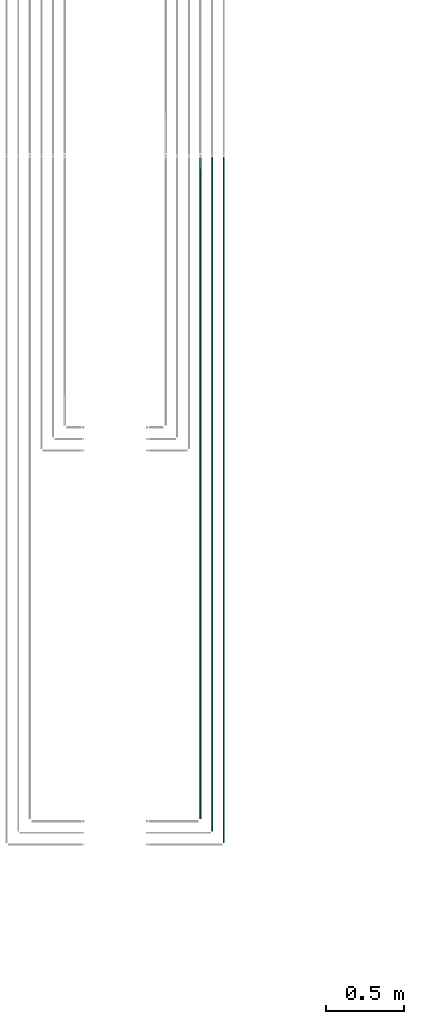
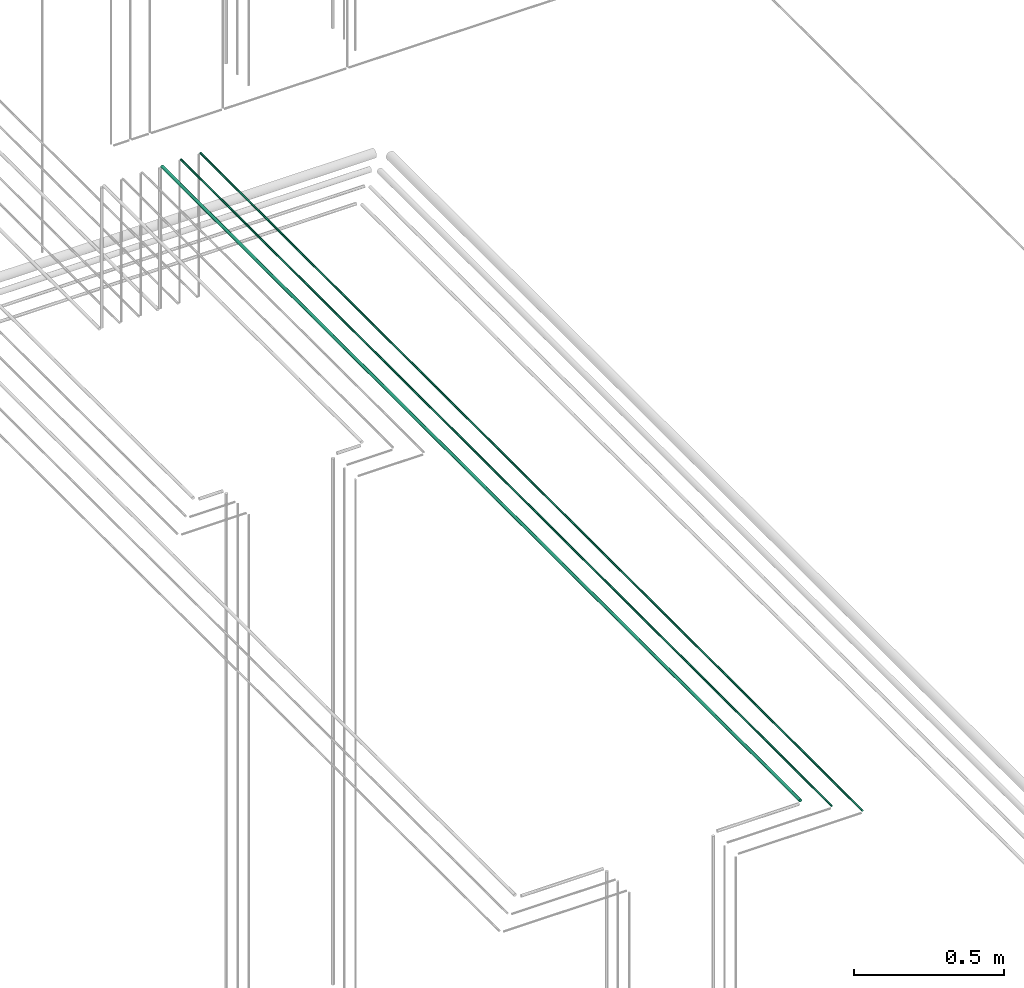
# One storey, part 59 of 331: 3 flow segments.
"""IFC2X3 building model written with IfcOpenShell, lengths in millimetres."""

from ifc_helpers import new_model, entity, si_unit, converted_unit, derived_unit, direction, frame, frame_2d, origin, origin_2d_with_axis, place, context, subcontext, project, spatial, circle, extrude, type_object, element, save


model = new_model("IFC2X3")

# Units and contexts
model_context = context("Model", 3, precision=0.01, world=origin(), true_north=direction((6.12303176911189e-17, 1.0)))
body_context = subcontext(model_context, "Body", "Model", "MODEL_VIEW")
ifc_project = project(units=[si_unit("LENGTHUNIT", "METRE", prefix="MILLI"), si_unit("AREAUNIT", "SQUARE_METRE"), si_unit("VOLUMEUNIT", "CUBIC_METRE"), converted_unit("PLANEANGLEUNIT", "DEGREE", entity("IfcRatioMeasure", 0.0174532925199433), si_unit("PLANEANGLEUNIT", "RADIAN"), dimensions=[0, 0, 0, 0, 0, 0, 0]), si_unit("MASSUNIT", "GRAM", prefix="KILO"), derived_unit("MASSDENSITYUNIT", [(si_unit("MASSUNIT", "GRAM", prefix="KILO"), 1), (si_unit("LENGTHUNIT", "METRE"), -3)]), derived_unit("MOMENTOFINERTIAUNIT", [(si_unit("LENGTHUNIT", "METRE"), 4)]), si_unit("TIMEUNIT", "SECOND"), si_unit("FREQUENCYUNIT", "HERTZ"), si_unit("THERMODYNAMICTEMPERATUREUNIT", "DEGREE_CELSIUS"), derived_unit("THERMALTRANSMITTANCEUNIT", [(si_unit("MASSUNIT", "GRAM", prefix="KILO"), 1), (si_unit("THERMODYNAMICTEMPERATUREUNIT", "KELVIN"), -1), (si_unit("TIMEUNIT", "SECOND"), -3)]), derived_unit("VOLUMETRICFLOWRATEUNIT", [(si_unit("LENGTHUNIT", "METRE"), 3), (si_unit("TIMEUNIT", "SECOND"), -1)]), derived_unit("MASSFLOWRATEUNIT", [(si_unit("MASSUNIT", "GRAM", prefix="KILO"), 1), (si_unit("TIMEUNIT", "SECOND"), -1)]), derived_unit("ROTATIONALFREQUENCYUNIT", [(si_unit("TIMEUNIT", "SECOND"), -1)]), si_unit("ELECTRICCURRENTUNIT", "AMPERE"), si_unit("ELECTRICVOLTAGEUNIT", "VOLT"), si_unit("POWERUNIT", "WATT"), si_unit("FORCEUNIT", "NEWTON", prefix="KILO"), si_unit("ILLUMINANCEUNIT", "LUX"), si_unit("LUMINOUSFLUXUNIT", "LUMEN"), si_unit("LUMINOUSINTENSITYUNIT", "CANDELA"), derived_unit("USERDEFINED", [(si_unit("MASSUNIT", "GRAM", prefix="KILO"), -1), (si_unit("LENGTHUNIT", "METRE"), -2), (si_unit("TIMEUNIT", "SECOND"), 3), (si_unit("LUMINOUSFLUXUNIT", "LUMEN"), 1)]), derived_unit("LINEARVELOCITYUNIT", [(si_unit("LENGTHUNIT", "METRE"), 1), (si_unit("TIMEUNIT", "SECOND"), -1)]), si_unit("PRESSUREUNIT", "PASCAL"), derived_unit("USERDEFINED", [(si_unit("LENGTHUNIT", "METRE"), -2), (si_unit("MASSUNIT", "GRAM", prefix="KILO"), 1), (si_unit("TIMEUNIT", "SECOND"), -2)]), derived_unit("LINEARFORCEUNIT", [(si_unit("MASSUNIT", "GRAM", prefix="KILO"), 1), (si_unit("LENGTHUNIT", "METRE"), 1), (si_unit("TIMEUNIT", "SECOND"), -2), (si_unit("LENGTHUNIT", "METRE"), -1)]), derived_unit("PLANARFORCEUNIT", [(si_unit("MASSUNIT", "GRAM", prefix="KILO"), 1), (si_unit("LENGTHUNIT", "METRE"), 1), (si_unit("TIMEUNIT", "SECOND"), -2), (si_unit("LENGTHUNIT", "METRE"), -2)])], contexts=[model_context])

# Site, building, storey
site_placement = place(None, frame((0.0, -0.00077364408347762, 0.0)))
site = spatial("IfcSite", under=ifc_project, at=site_placement, CompositionType="ELEMENT")
building_placement = place(site_placement, origin())
building = spatial("IfcBuilding", under=site, at=building_placement, CompositionType="ELEMENT")
storey_placement = place(building_placement, origin())
storey = spatial("IfcBuildingStorey", under=building, at=storey_placement, CompositionType="ELEMENT", Elevation=0.0)

# Flow segments
pipe_segment_type = type_object("IfcPipeSegmentType", PredefinedType="NOTDEFINED")
flow_segment_1_placement = place(storey_placement, frame((53913.5223318378, 1365.4887670795, 15142.4047277641)))
element("IfcFlowSegment", 1, at=flow_segment_1_placement, inside=storey, type_object=pipe_segment_type, context=body_context, shape_type="SweptSolid", body=[
    extrude(circle(Radius=6.0, at=frame_2d((0.0, 2.16573425859679e-12), x_axis=(1.0, 0.0))), frame((7.59527223591454, 0.0, 7.59527223591887), z_axis=(0.0, 1.0, 0.0), x_axis=(1.0, 0.0, 0.0)), (0.0, 0.0, 1.0), 4264.13179674785),
])
flow_segment_2_placement = place(storey_placement, frame((53990.5223318378, 1286.48876707969, 15144.4047277641)))
element("IfcFlowSegment", 2, at=flow_segment_2_placement, inside=storey, type_object=pipe_segment_type, context=body_context, shape_type="SweptSolid", body=[
    extrude(circle(Radius=4.0, at=origin_2d_with_axis()), frame((5.59527223591499, 0.0, 5.59527223591499), z_axis=(0.0, 1.0, 0.0), x_axis=(1.0, 0.0, 0.0)), (0.0, 0.0, 1.0), 4347.13179674766),
])
flow_segment_3_placement = place(storey_placement, frame((54065.5223318378, 1211.48876707957, 15144.4047277641)))
element("IfcFlowSegment", 3, at=flow_segment_3_placement, inside=storey, type_object=pipe_segment_type, context=body_context, shape_type="SweptSolid", body=[
    extrude(circle(Radius=4.0, at=origin_2d_with_axis()), frame((5.59527223591499, 0.0, 5.59527223591499), z_axis=(0.0, 1.0, 0.0), x_axis=(1.0, 0.0, 0.0)), (0.0, 0.0, 1.0), 4422.13179674778),
])

save(model, "model.ifc")
